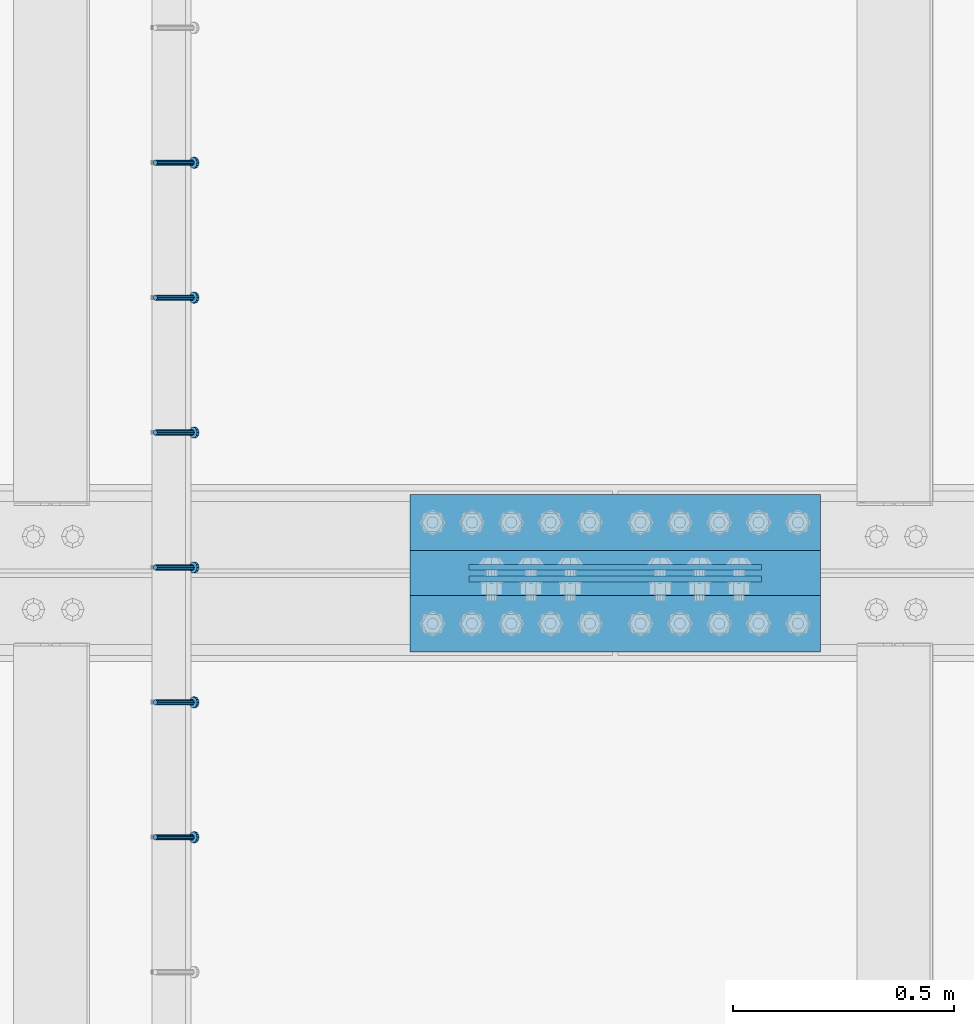
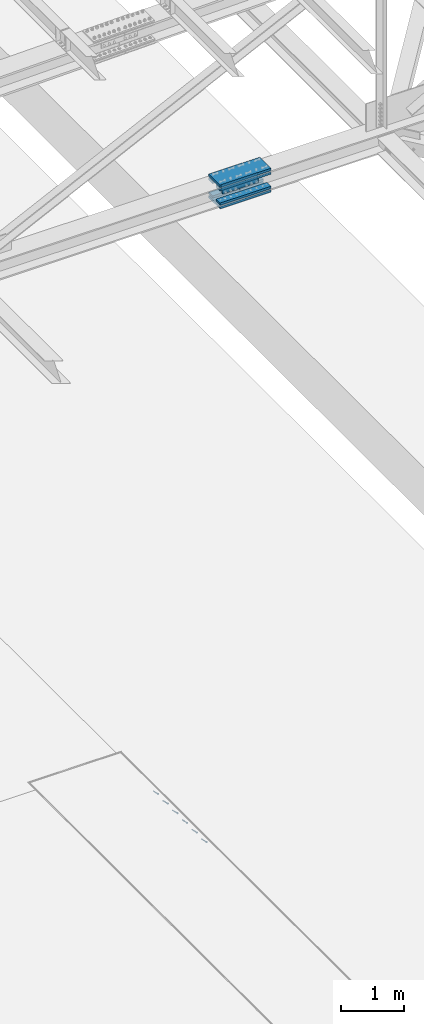
# One storey, part 2348 of 3843: 8 beams, 6 members, 2 elements without a shape of their own.
"""IFC2X3 building model written with IfcOpenShell, lengths in millimetres."""

from ifc_helpers import new_model, si_unit, frame, origin_with_axes, place, context, subcontext, project, spatial, faceted_brep, material, type_object, element, aggregate, save


model = new_model("IFC2X3")

# Units and contexts
model_context = context("Model", 3, precision=1e-05, world=origin_with_axes())
body_context = subcontext(model_context, "Body", "Model", "MODEL_VIEW")
ifc_project = project(units=[si_unit("LENGTHUNIT", "METRE", prefix="MILLI"), si_unit("AREAUNIT", "SQUARE_METRE"), si_unit("VOLUMEUNIT", "CUBIC_METRE"), si_unit("MASSUNIT", "GRAM", prefix="KILO"), si_unit("TIMEUNIT", "SECOND"), si_unit("PLANEANGLEUNIT", "RADIAN"), si_unit("SOLIDANGLEUNIT", "STERADIAN"), si_unit("THERMODYNAMICTEMPERATUREUNIT", "DEGREE_CELSIUS"), si_unit("LUMINOUSINTENSITYUNIT", "LUMEN")], contexts=[model_context])

# Site, building, storey
site_placement = place(None, origin_with_axes())
site = spatial("IfcSite", under=ifc_project, at=site_placement, CompositionType="ELEMENT")
building_placement = place(site_placement, origin_with_axes())
building = spatial("IfcBuilding", under=site, at=building_placement, Name="Undefined", CompositionType="ELEMENT")
storey_placement = place(building_placement, origin_with_axes())
storey = spatial("IfcBuildingStorey", under=building, at=storey_placement, Name="Undefined", CompositionType="ELEMENT", Elevation=0.0)

# Assembly, members
assembly_1_placement = place(storey_placement, origin_with_axes())
assembly_1 = element("IfcElementAssembly", 1, at=assembly_1_placement, inside=storey, Name="EMBED_ANGLE", AssemblyPlace="NOTDEFINED", PredefinedType="RIGID_FRAME")
ifc_material_1 = material(Name="STEEL/A108")
member_type = type_object("IfcMemberType", PredefinedType="NOTDEFINED")
member_1_placement = place(assembly_1_placement, frame((66677.3495, 49961.800201416, 30446.6625), z_axis=(0.0, 1.0, 0.0), x_axis=(0.707106781186548, 0.0, -0.707106781186548)))
member_1 = element("IfcMember", 2, at=member_1_placement, type_object=member_type, material=ifc_material_1, Name="HEADED STUD ANCHOR", context=body_context, shape_type="Brep", body=[
    faceted_brep([(7.27595761418343e-12, -3.18000006675175, 5.5), (0.0, -5.49999999998363, 3.1800000667572), (118.110000000976, -5.49999999999091, 3.1800000667572), (118.110000000983, -3.18000006675175, 5.5), (0.0, -6.3499999046162, 0.0), (118.110000000968, -6.34999990461256, 0.0), (0.0, -5.49999999998363, -3.1800000667572), (118.110000000976, -5.49999999999091, -3.1800000667572), (7.27595761418343e-12, -3.18000006675175, -5.5), (118.110000000983, -3.18000006675175, -5.5), (7.27595761418343e-12, -1.81898940354586e-12, -6.34999990463257), (118.110000000968, -1.81898940354586e-12, -6.34999990463257), (0.0, 3.18000006675175, -5.5), (118.110000000968, 3.18000006674811, -5.5), (7.27595761418343e-12, 5.49999999998363, -3.1800000667572), (118.110000000983, 5.49999999998363, -3.1800000667572), (7.27595761418343e-12, 6.3499999046162, 0.0), (118.110000000976, 6.34999990461256, 0.0), (7.27595761418343e-12, 5.49999999998363, 3.1800000667572), (118.110000000983, 5.49999999998363, 3.1800000667572), (0.0, 3.18000006675175, 5.5), (118.110000000968, 3.18000006674811, 5.5), (7.27595761418343e-12, -1.81898940354586e-12, 6.34999990463257), (118.110000000968, -1.81898940354586e-12, 6.34999990463257), (120.650000000991, -10.9899997710909, 6.34999990463257), (120.650000000998, -6.34000015257152, 10.9899997711182), (120.650000000991, -12.6999998092379, 0.0), (120.650000000991, -10.9899997710909, -6.34999990463257), (120.650000000998, -6.34000015257152, -10.9899997711182), (120.650000000991, -1.81898940354586e-12, -12.6899995803833), (120.650000000991, 6.34000015257152, -10.9899997711182), (120.650000000998, 10.9899997710909, -6.34999990463257), (120.650000000991, 12.6999998092342, 0.0), (120.650000000998, 10.9899997710909, 6.34999990463257), (120.650000000991, 6.34000015257152, 10.9899997711182), (120.650000000991, -1.81898940354586e-12, 12.6899995803833), (127.000000001048, -10.9899997710945, 6.34999990463257), (127.000000001048, -6.34000015257152, 10.9899997711182), (127.000000001048, -12.6999998092342, 0.0), (127.000000001048, -10.9899997710945, -6.34999990463257), (127.000000001048, -6.34000015257152, -10.9899997711182), (127.000000001048, 1.81898940354586e-12, -12.6899995803833), (127.000000001048, 6.34000015256788, -10.9899997711182), (127.000000001048, 10.9899997710909, -6.34999990463257), (127.000000001048, 12.6999998092379, 0.0), (127.000000001048, 10.9899997710909, 6.34999990463257), (127.000000001048, 6.34000015256788, 10.9899997711182), (127.000000001048, 1.81898940354586e-12, 12.6899995803833)], [[[0, 1, 2, 3]], [[1, 4, 5, 2]], [[4, 6, 7, 5]], [[6, 8, 9, 7]], [[8, 10, 11, 9]], [[10, 12, 13, 11]], [[12, 14, 15, 13]], [[14, 16, 17, 15]], [[16, 18, 19, 17]], [[18, 20, 21, 19]], [[20, 22, 23, 21]], [[22, 0, 3, 23]], [[22, 20, 18, 16, 14, 12, 10, 8, 6, 4, 1, 0]], [[3, 2, 24, 25]], [[2, 5, 26, 24]], [[5, 7, 27, 26]], [[7, 9, 28, 27]], [[9, 11, 29, 28]], [[11, 13, 30, 29]], [[13, 15, 31, 30]], [[15, 17, 32, 31]], [[17, 19, 33, 32]], [[19, 21, 34, 33]], [[21, 23, 35, 34]], [[23, 3, 25, 35]], [[25, 24, 36, 37]], [[24, 26, 38, 36]], [[26, 27, 39, 38]], [[27, 28, 40, 39]], [[28, 29, 41, 40]], [[29, 30, 42, 41]], [[30, 31, 43, 42]], [[31, 32, 44, 43]], [[32, 33, 45, 44]], [[33, 34, 46, 45]], [[34, 35, 47, 46]], [[35, 25, 37, 47]], [[38, 39, 40, 41, 42, 43, 44, 45, 46, 47, 37, 36]]]),
])
member_2_placement = place(assembly_1_placement, frame((66677.3495, 50266.600201416, 30446.6625), z_axis=(0.0, 1.0, 0.0), x_axis=(0.707106781186548, 0.0, -0.707106781186548)))
member_2 = element("IfcMember", 3, at=member_2_placement, type_object=member_type, material=ifc_material_1, Name="HEADED STUD ANCHOR", context=body_context, shape_type="Brep", body=[
    faceted_brep([(7.27595761418343e-12, -3.18000006675175, 5.5), (0.0, -5.49999999998363, 3.1800000667572), (118.110000000976, -5.49999999999091, 3.1800000667572), (118.110000000983, -3.18000006675175, 5.5), (0.0, -6.3499999046162, 0.0), (118.110000000968, -6.34999990461256, 0.0), (0.0, -5.49999999998363, -3.1800000667572), (118.110000000976, -5.49999999999091, -3.1800000667572), (7.27595761418343e-12, -3.18000006675175, -5.5), (118.110000000983, -3.18000006675175, -5.5), (7.27595761418343e-12, -1.81898940354586e-12, -6.34999990463257), (118.110000000968, -1.81898940354586e-12, -6.34999990463257), (0.0, 3.18000006675175, -5.5), (118.110000000968, 3.18000006674811, -5.5), (7.27595761418343e-12, 5.49999999998363, -3.1800000667572), (118.110000000983, 5.49999999998363, -3.1800000667572), (7.27595761418343e-12, 6.3499999046162, 0.0), (118.110000000976, 6.34999990461256, 0.0), (7.27595761418343e-12, 5.49999999998363, 3.1800000667572), (118.110000000983, 5.49999999998363, 3.1800000667572), (0.0, 3.18000006675175, 5.5), (118.110000000968, 3.18000006674811, 5.5), (7.27595761418343e-12, -1.81898940354586e-12, 6.34999990463257), (118.110000000968, -1.81898940354586e-12, 6.34999990463257), (120.650000000991, -10.9899997710909, 6.34999990463257), (120.650000000998, -6.34000015257152, 10.9899997711182), (120.650000000991, -12.6999998092379, 0.0), (120.650000000991, -10.9899997710909, -6.34999990463257), (120.650000000998, -6.34000015257152, -10.9899997711182), (120.650000000991, -1.81898940354586e-12, -12.6899995803833), (120.650000000991, 6.34000015257152, -10.9899997711182), (120.650000000998, 10.9899997710909, -6.34999990463257), (120.650000000991, 12.6999998092342, 0.0), (120.650000000998, 10.9899997710909, 6.34999990463257), (120.650000000991, 6.34000015257152, 10.9899997711182), (120.650000000991, -1.81898940354586e-12, 12.6899995803833), (127.000000001048, -10.9899997710945, 6.34999990463257), (127.000000001048, -6.34000015257152, 10.9899997711182), (127.000000001048, -12.6999998092342, 0.0), (127.000000001048, -10.9899997710945, -6.34999990463257), (127.000000001048, -6.34000015257152, -10.9899997711182), (127.000000001048, 1.81898940354586e-12, -12.6899995803833), (127.000000001048, 6.34000015256788, -10.9899997711182), (127.000000001048, 10.9899997710909, -6.34999990463257), (127.000000001048, 12.6999998092379, 0.0), (127.000000001048, 10.9899997710909, 6.34999990463257), (127.000000001048, 6.34000015256788, 10.9899997711182), (127.000000001048, 1.81898940354586e-12, 12.6899995803833)], [[[0, 1, 2, 3]], [[1, 4, 5, 2]], [[4, 6, 7, 5]], [[6, 8, 9, 7]], [[8, 10, 11, 9]], [[10, 12, 13, 11]], [[12, 14, 15, 13]], [[14, 16, 17, 15]], [[16, 18, 19, 17]], [[18, 20, 21, 19]], [[20, 22, 23, 21]], [[22, 0, 3, 23]], [[22, 20, 18, 16, 14, 12, 10, 8, 6, 4, 1, 0]], [[3, 2, 24, 25]], [[2, 5, 26, 24]], [[5, 7, 27, 26]], [[7, 9, 28, 27]], [[9, 11, 29, 28]], [[11, 13, 30, 29]], [[13, 15, 31, 30]], [[15, 17, 32, 31]], [[17, 19, 33, 32]], [[19, 21, 34, 33]], [[21, 23, 35, 34]], [[23, 3, 25, 35]], [[25, 24, 36, 37]], [[24, 26, 38, 36]], [[26, 27, 39, 38]], [[27, 28, 40, 39]], [[28, 29, 41, 40]], [[29, 30, 42, 41]], [[30, 31, 43, 42]], [[31, 32, 44, 43]], [[32, 33, 45, 44]], [[33, 34, 46, 45]], [[34, 35, 47, 46]], [[35, 25, 37, 47]], [[38, 39, 40, 41, 42, 43, 44, 45, 46, 47, 37, 36]]]),
])
member_3_placement = place(assembly_1_placement, frame((66677.3495, 50571.400201416, 30446.6625), z_axis=(0.0, 1.0, 0.0), x_axis=(0.707106781186548, 0.0, -0.707106781186548)))
member_3 = element("IfcMember", 4, at=member_3_placement, type_object=member_type, material=ifc_material_1, Name="HEADED STUD ANCHOR", context=body_context, shape_type="Brep", body=[
    faceted_brep([(7.27595761418343e-12, -3.18000006675175, 5.5), (0.0, -5.49999999998363, 3.1800000667572), (118.110000000976, -5.49999999999091, 3.1800000667572), (118.110000000983, -3.18000006675175, 5.5), (0.0, -6.3499999046162, 0.0), (118.110000000968, -6.34999990461256, 0.0), (0.0, -5.49999999998363, -3.1800000667572), (118.110000000976, -5.49999999999091, -3.1800000667572), (7.27595761418343e-12, -3.18000006675175, -5.5), (118.110000000983, -3.18000006675175, -5.5), (7.27595761418343e-12, -1.81898940354586e-12, -6.34999990463257), (118.110000000968, -1.81898940354586e-12, -6.34999990463257), (0.0, 3.18000006675175, -5.5), (118.110000000968, 3.18000006674811, -5.5), (7.27595761418343e-12, 5.49999999998363, -3.1800000667572), (118.110000000983, 5.49999999998363, -3.1800000667572), (7.27595761418343e-12, 6.3499999046162, 0.0), (118.110000000976, 6.34999990461256, 0.0), (7.27595761418343e-12, 5.49999999998363, 3.1800000667572), (118.110000000983, 5.49999999998363, 3.1800000667572), (0.0, 3.18000006675175, 5.5), (118.110000000968, 3.18000006674811, 5.5), (7.27595761418343e-12, -1.81898940354586e-12, 6.34999990463257), (118.110000000968, -1.81898940354586e-12, 6.34999990463257), (120.650000000991, -10.9899997710909, 6.34999990463257), (120.650000000998, -6.34000015257152, 10.9899997711182), (120.650000000991, -12.6999998092379, 0.0), (120.650000000991, -10.9899997710909, -6.34999990463257), (120.650000000998, -6.34000015257152, -10.9899997711182), (120.650000000991, -1.81898940354586e-12, -12.6899995803833), (120.650000000991, 6.34000015257152, -10.9899997711182), (120.650000000998, 10.9899997710909, -6.34999990463257), (120.650000000991, 12.6999998092342, 0.0), (120.650000000998, 10.9899997710909, 6.34999990463257), (120.650000000991, 6.34000015257152, 10.9899997711182), (120.650000000991, -1.81898940354586e-12, 12.6899995803833), (127.000000001048, -10.9899997710945, 6.34999990463257), (127.000000001048, -6.34000015257152, 10.9899997711182), (127.000000001048, -12.6999998092342, 0.0), (127.000000001048, -10.9899997710945, -6.34999990463257), (127.000000001048, -6.34000015257152, -10.9899997711182), (127.000000001048, 1.81898940354586e-12, -12.6899995803833), (127.000000001048, 6.34000015256788, -10.9899997711182), (127.000000001048, 10.9899997710909, -6.34999990463257), (127.000000001048, 12.6999998092379, 0.0), (127.000000001048, 10.9899997710909, 6.34999990463257), (127.000000001048, 6.34000015256788, 10.9899997711182), (127.000000001048, 1.81898940354586e-12, 12.6899995803833)], [[[0, 1, 2, 3]], [[1, 4, 5, 2]], [[4, 6, 7, 5]], [[6, 8, 9, 7]], [[8, 10, 11, 9]], [[10, 12, 13, 11]], [[12, 14, 15, 13]], [[14, 16, 17, 15]], [[16, 18, 19, 17]], [[18, 20, 21, 19]], [[20, 22, 23, 21]], [[22, 0, 3, 23]], [[22, 20, 18, 16, 14, 12, 10, 8, 6, 4, 1, 0]], [[3, 2, 24, 25]], [[2, 5, 26, 24]], [[5, 7, 27, 26]], [[7, 9, 28, 27]], [[9, 11, 29, 28]], [[11, 13, 30, 29]], [[13, 15, 31, 30]], [[15, 17, 32, 31]], [[17, 19, 33, 32]], [[19, 21, 34, 33]], [[21, 23, 35, 34]], [[23, 3, 25, 35]], [[25, 24, 36, 37]], [[24, 26, 38, 36]], [[26, 27, 39, 38]], [[27, 28, 40, 39]], [[28, 29, 41, 40]], [[29, 30, 42, 41]], [[30, 31, 43, 42]], [[31, 32, 44, 43]], [[32, 33, 45, 44]], [[33, 34, 46, 45]], [[34, 35, 47, 46]], [[35, 25, 37, 47]], [[38, 39, 40, 41, 42, 43, 44, 45, 46, 47, 37, 36]]]),
])
member_4_placement = place(assembly_1_placement, frame((66677.3495, 50876.200201416, 30446.6625), z_axis=(0.0, 1.0, 0.0), x_axis=(0.707106781186548, 0.0, -0.707106781186548)))
member_4 = element("IfcMember", 5, at=member_4_placement, type_object=member_type, material=ifc_material_1, Name="HEADED STUD ANCHOR", context=body_context, shape_type="Brep", body=[
    faceted_brep([(7.27595761418343e-12, -3.18000006675175, 5.5), (0.0, -5.49999999998363, 3.1800000667572), (118.110000000976, -5.49999999999091, 3.1800000667572), (118.110000000983, -3.18000006675175, 5.5), (0.0, -6.3499999046162, 0.0), (118.110000000968, -6.34999990461256, 0.0), (0.0, -5.49999999998363, -3.1800000667572), (118.110000000976, -5.49999999999091, -3.1800000667572), (7.27595761418343e-12, -3.18000006675175, -5.5), (118.110000000983, -3.18000006675175, -5.5), (7.27595761418343e-12, -1.81898940354586e-12, -6.34999990463257), (118.110000000968, -1.81898940354586e-12, -6.34999990463257), (0.0, 3.18000006675175, -5.5), (118.110000000968, 3.18000006674811, -5.5), (7.27595761418343e-12, 5.49999999998363, -3.1800000667572), (118.110000000983, 5.49999999998363, -3.1800000667572), (7.27595761418343e-12, 6.3499999046162, 0.0), (118.110000000976, 6.34999990461256, 0.0), (7.27595761418343e-12, 5.49999999998363, 3.1800000667572), (118.110000000983, 5.49999999998363, 3.1800000667572), (0.0, 3.18000006675175, 5.5), (118.110000000968, 3.18000006674811, 5.5), (7.27595761418343e-12, -1.81898940354586e-12, 6.34999990463257), (118.110000000968, -1.81898940354586e-12, 6.34999990463257), (120.650000000991, -10.9899997710909, 6.34999990463257), (120.650000000998, -6.34000015257152, 10.9899997711182), (120.650000000991, -12.6999998092379, 0.0), (120.650000000991, -10.9899997710909, -6.34999990463257), (120.650000000998, -6.34000015257152, -10.9899997711182), (120.650000000991, -1.81898940354586e-12, -12.6899995803833), (120.650000000991, 6.34000015257152, -10.9899997711182), (120.650000000998, 10.9899997710909, -6.34999990463257), (120.650000000991, 12.6999998092342, 0.0), (120.650000000998, 10.9899997710909, 6.34999990463257), (120.650000000991, 6.34000015257152, 10.9899997711182), (120.650000000991, -1.81898940354586e-12, 12.6899995803833), (127.000000001048, -10.9899997710945, 6.34999990463257), (127.000000001048, -6.34000015257152, 10.9899997711182), (127.000000001048, -12.6999998092342, 0.0), (127.000000001048, -10.9899997710945, -6.34999990463257), (127.000000001048, -6.34000015257152, -10.9899997711182), (127.000000001048, 1.81898940354586e-12, -12.6899995803833), (127.000000001048, 6.34000015256788, -10.9899997711182), (127.000000001048, 10.9899997710909, -6.34999990463257), (127.000000001048, 12.6999998092379, 0.0), (127.000000001048, 10.9899997710909, 6.34999990463257), (127.000000001048, 6.34000015256788, 10.9899997711182), (127.000000001048, 1.81898940354586e-12, 12.6899995803833)], [[[0, 1, 2, 3]], [[1, 4, 5, 2]], [[4, 6, 7, 5]], [[6, 8, 9, 7]], [[8, 10, 11, 9]], [[10, 12, 13, 11]], [[12, 14, 15, 13]], [[14, 16, 17, 15]], [[16, 18, 19, 17]], [[18, 20, 21, 19]], [[20, 22, 23, 21]], [[22, 0, 3, 23]], [[22, 20, 18, 16, 14, 12, 10, 8, 6, 4, 1, 0]], [[3, 2, 24, 25]], [[2, 5, 26, 24]], [[5, 7, 27, 26]], [[7, 9, 28, 27]], [[9, 11, 29, 28]], [[11, 13, 30, 29]], [[13, 15, 31, 30]], [[15, 17, 32, 31]], [[17, 19, 33, 32]], [[19, 21, 34, 33]], [[21, 23, 35, 34]], [[23, 3, 25, 35]], [[25, 24, 36, 37]], [[24, 26, 38, 36]], [[26, 27, 39, 38]], [[27, 28, 40, 39]], [[28, 29, 41, 40]], [[29, 30, 42, 41]], [[30, 31, 43, 42]], [[31, 32, 44, 43]], [[32, 33, 45, 44]], [[33, 34, 46, 45]], [[34, 35, 47, 46]], [[35, 25, 37, 47]], [[38, 39, 40, 41, 42, 43, 44, 45, 46, 47, 37, 36]]]),
])
member_5_placement = place(assembly_1_placement, frame((66677.3495, 51181.000201416, 30446.6625), z_axis=(0.0, 1.0, 0.0), x_axis=(0.707106781186548, 0.0, -0.707106781186548)))
member_5 = element("IfcMember", 6, at=member_5_placement, type_object=member_type, material=ifc_material_1, Name="HEADED STUD ANCHOR", context=body_context, shape_type="Brep", body=[
    faceted_brep([(7.27595761418343e-12, -3.18000006675175, 5.5), (0.0, -5.49999999998363, 3.1800000667572), (118.110000000976, -5.49999999999091, 3.1800000667572), (118.110000000983, -3.18000006675175, 5.5), (0.0, -6.3499999046162, 0.0), (118.110000000968, -6.34999990461256, 0.0), (0.0, -5.49999999998363, -3.1800000667572), (118.110000000976, -5.49999999999091, -3.1800000667572), (7.27595761418343e-12, -3.18000006675175, -5.5), (118.110000000983, -3.18000006675175, -5.5), (7.27595761418343e-12, -1.81898940354586e-12, -6.34999990463257), (118.110000000968, -1.81898940354586e-12, -6.34999990463257), (0.0, 3.18000006675175, -5.5), (118.110000000968, 3.18000006674811, -5.5), (7.27595761418343e-12, 5.49999999998363, -3.1800000667572), (118.110000000983, 5.49999999998363, -3.1800000667572), (7.27595761418343e-12, 6.3499999046162, 0.0), (118.110000000976, 6.34999990461256, 0.0), (7.27595761418343e-12, 5.49999999998363, 3.1800000667572), (118.110000000983, 5.49999999998363, 3.1800000667572), (0.0, 3.18000006675175, 5.5), (118.110000000968, 3.18000006674811, 5.5), (7.27595761418343e-12, -1.81898940354586e-12, 6.34999990463257), (118.110000000968, -1.81898940354586e-12, 6.34999990463257), (120.650000000991, -10.9899997710909, 6.34999990463257), (120.650000000998, -6.34000015257152, 10.9899997711182), (120.650000000991, -12.6999998092379, 0.0), (120.650000000991, -10.9899997710909, -6.34999990463257), (120.650000000998, -6.34000015257152, -10.9899997711182), (120.650000000991, -1.81898940354586e-12, -12.6899995803833), (120.650000000991, 6.34000015257152, -10.9899997711182), (120.650000000998, 10.9899997710909, -6.34999990463257), (120.650000000991, 12.6999998092342, 0.0), (120.650000000998, 10.9899997710909, 6.34999990463257), (120.650000000991, 6.34000015257152, 10.9899997711182), (120.650000000991, -1.81898940354586e-12, 12.6899995803833), (127.000000001048, -10.9899997710945, 6.34999990463257), (127.000000001048, -6.34000015257152, 10.9899997711182), (127.000000001048, -12.6999998092342, 0.0), (127.000000001048, -10.9899997710945, -6.34999990463257), (127.000000001048, -6.34000015257152, -10.9899997711182), (127.000000001048, 1.81898940354586e-12, -12.6899995803833), (127.000000001048, 6.34000015256788, -10.9899997711182), (127.000000001048, 10.9899997710909, -6.34999990463257), (127.000000001048, 12.6999998092379, 0.0), (127.000000001048, 10.9899997710909, 6.34999990463257), (127.000000001048, 6.34000015256788, 10.9899997711182), (127.000000001048, 1.81898940354586e-12, 12.6899995803833)], [[[0, 1, 2, 3]], [[1, 4, 5, 2]], [[4, 6, 7, 5]], [[6, 8, 9, 7]], [[8, 10, 11, 9]], [[10, 12, 13, 11]], [[12, 14, 15, 13]], [[14, 16, 17, 15]], [[16, 18, 19, 17]], [[18, 20, 21, 19]], [[20, 22, 23, 21]], [[22, 0, 3, 23]], [[22, 20, 18, 16, 14, 12, 10, 8, 6, 4, 1, 0]], [[3, 2, 24, 25]], [[2, 5, 26, 24]], [[5, 7, 27, 26]], [[7, 9, 28, 27]], [[9, 11, 29, 28]], [[11, 13, 30, 29]], [[13, 15, 31, 30]], [[15, 17, 32, 31]], [[17, 19, 33, 32]], [[19, 21, 34, 33]], [[21, 23, 35, 34]], [[23, 3, 25, 35]], [[25, 24, 36, 37]], [[24, 26, 38, 36]], [[26, 27, 39, 38]], [[27, 28, 40, 39]], [[28, 29, 41, 40]], [[29, 30, 42, 41]], [[30, 31, 43, 42]], [[31, 32, 44, 43]], [[32, 33, 45, 44]], [[33, 34, 46, 45]], [[34, 35, 47, 46]], [[35, 25, 37, 47]], [[38, 39, 40, 41, 42, 43, 44, 45, 46, 47, 37, 36]]]),
])
member_6_placement = place(assembly_1_placement, frame((66677.3495, 51485.800201416, 30446.6625), z_axis=(0.0, 1.0, 0.0), x_axis=(0.707106781186548, 0.0, -0.707106781186548)))
member_6 = element("IfcMember", 7, at=member_6_placement, type_object=member_type, material=ifc_material_1, Name="HEADED STUD ANCHOR", context=body_context, shape_type="Brep", body=[
    faceted_brep([(7.27595761418343e-12, -3.18000006675175, 5.5), (0.0, -5.49999999998363, 3.1800000667572), (118.110000000976, -5.49999999999091, 3.1800000667572), (118.110000000983, -3.18000006675175, 5.5), (0.0, -6.3499999046162, 0.0), (118.110000000968, -6.34999990461256, 0.0), (0.0, -5.49999999998363, -3.1800000667572), (118.110000000976, -5.49999999999091, -3.1800000667572), (7.27595761418343e-12, -3.18000006675175, -5.5), (118.110000000983, -3.18000006675175, -5.5), (7.27595761418343e-12, -1.81898940354586e-12, -6.34999990463257), (118.110000000968, -1.81898940354586e-12, -6.34999990463257), (0.0, 3.18000006675175, -5.5), (118.110000000968, 3.18000006674811, -5.5), (7.27595761418343e-12, 5.49999999998363, -3.1800000667572), (118.110000000983, 5.49999999998363, -3.1800000667572), (7.27595761418343e-12, 6.3499999046162, 0.0), (118.110000000976, 6.34999990461256, 0.0), (7.27595761418343e-12, 5.49999999998363, 3.1800000667572), (118.110000000983, 5.49999999998363, 3.1800000667572), (0.0, 3.18000006675175, 5.5), (118.110000000968, 3.18000006674811, 5.5), (7.27595761418343e-12, -1.81898940354586e-12, 6.34999990463257), (118.110000000968, -1.81898940354586e-12, 6.34999990463257), (120.650000000991, -10.9899997710909, 6.34999990463257), (120.650000000998, -6.34000015257152, 10.9899997711182), (120.650000000991, -12.6999998092379, 0.0), (120.650000000991, -10.9899997710909, -6.34999990463257), (120.650000000998, -6.34000015257152, -10.9899997711182), (120.650000000991, -1.81898940354586e-12, -12.6899995803833), (120.650000000991, 6.34000015257152, -10.9899997711182), (120.650000000998, 10.9899997710909, -6.34999990463257), (120.650000000991, 12.6999998092342, 0.0), (120.650000000998, 10.9899997710909, 6.34999990463257), (120.650000000991, 6.34000015257152, 10.9899997711182), (120.650000000991, -1.81898940354586e-12, 12.6899995803833), (127.000000001048, -10.9899997710945, 6.34999990463257), (127.000000001048, -6.34000015257152, 10.9899997711182), (127.000000001048, -12.6999998092342, 0.0), (127.000000001048, -10.9899997710945, -6.34999990463257), (127.000000001048, -6.34000015257152, -10.9899997711182), (127.000000001048, 1.81898940354586e-12, -12.6899995803833), (127.000000001048, 6.34000015256788, -10.9899997711182), (127.000000001048, 10.9899997710909, -6.34999990463257), (127.000000001048, 12.6999998092379, 0.0), (127.000000001048, 10.9899997710909, 6.34999990463257), (127.000000001048, 6.34000015256788, 10.9899997711182), (127.000000001048, 1.81898940354586e-12, 12.6899995803833)], [[[0, 1, 2, 3]], [[1, 4, 5, 2]], [[4, 6, 7, 5]], [[6, 8, 9, 7]], [[8, 10, 11, 9]], [[10, 12, 13, 11]], [[12, 14, 15, 13]], [[14, 16, 17, 15]], [[16, 18, 19, 17]], [[18, 20, 21, 19]], [[20, 22, 23, 21]], [[22, 0, 3, 23]], [[22, 20, 18, 16, 14, 12, 10, 8, 6, 4, 1, 0]], [[3, 2, 24, 25]], [[2, 5, 26, 24]], [[5, 7, 27, 26]], [[7, 9, 28, 27]], [[9, 11, 29, 28]], [[11, 13, 30, 29]], [[13, 15, 31, 30]], [[15, 17, 32, 31]], [[17, 19, 33, 32]], [[19, 21, 34, 33]], [[21, 23, 35, 34]], [[23, 3, 25, 35]], [[25, 24, 36, 37]], [[24, 26, 38, 36]], [[26, 27, 39, 38]], [[27, 28, 40, 39]], [[28, 29, 41, 40]], [[29, 30, 42, 41]], [[30, 31, 43, 42]], [[31, 32, 44, 43]], [[32, 33, 45, 44]], [[33, 34, 46, 45]], [[34, 35, 47, 46]], [[35, 25, 37, 47]], [[38, 39, 40, 41, 42, 43, 44, 45, 46, 47, 37, 36]]]),
])
aggregate(assembly_1, [member_1, member_2, member_3, member_4, member_5, member_6])

# Assembly, beams
assembly_2_placement = place(storey_placement, origin_with_axes())
assembly_2 = element("IfcElementAssembly", 8, at=assembly_2_placement, inside=storey, Name="BEAM", AssemblyPlace="NOTDEFINED", PredefinedType="RIGID_FRAME")
ifc_material_2 = material(Name="STEEL/A572-50")
beam_type_1 = type_object("IfcBeamType", PredefinedType="NOTDEFINED")
beam_1_placement = place(assembly_2_placement, frame((68046.5999947969, 50572.1937469886, 42344.4237563787), z_axis=(-0.000178361000012955, 0.0, 0.999999984093677), x_axis=(-0.999999984093677, 0.0, -0.000178361000011789)))
beam_1 = element("IfcBeam", 9, at=beam_1_placement, type_object=beam_type_1, material=ifc_material_2, Name="PLATE", context=body_context, shape_type="Brep", body=[
    faceted_brep([(1.45519152283669e-11, 6.35000000000582, -88.8999999998996), (0.0, 6.34999999999854, 88.9000015258789), (660.399999982677, 6.35000000000582, 88.8999999999651), (660.399999982707, 6.35000000000582, -88.8999999998268), (0.0, -6.34999999999854, 88.9000015258789), (660.399999982677, -6.35000000000582, 88.8999999999651), (1.45519152283669e-11, -6.35000000000582, -88.8999999998996), (660.399999982707, -6.35000000000582, -88.8999999998268)], [[[0, 1, 2, 3]], [[1, 4, 5, 2]], [[4, 6, 7, 5]], [[6, 0, 3, 7]], [[5, 7, 3, 2]], [[6, 4, 1, 0]]]),
])
beam_2_placement = place(assembly_2_placement, frame((68046.5999947969, 50545.2062469886, 42344.4237563787), z_axis=(-0.000178361000012955, 0.0, 0.999999984093677), x_axis=(-0.999999984093677, 0.0, -0.000178361000011789)))
beam_2 = element("IfcBeam", 10, at=beam_2_placement, type_object=beam_type_1, material=ifc_material_2, Name="PLATE", context=body_context, shape_type="Brep", body=[
    faceted_brep([(1.45519152283669e-11, 6.35000000000582, -88.8999999998996), (0.0, 6.34999999999854, 88.9000015258789), (660.399999982677, 6.35000000000582, 88.8999999999651), (660.399999982707, 6.35000000000582, -88.8999999998268), (0.0, -6.34999999999854, 88.9000015258789), (660.399999982677, -6.35000000000582, 88.8999999999651), (1.45519152283669e-11, -6.35000000000582, -88.8999999998996), (660.399999982707, -6.35000000000582, -88.8999999998268)], [[[0, 1, 2, 3]], [[1, 4, 5, 2]], [[4, 6, 7, 5]], [[6, 0, 3, 7]], [[5, 7, 3, 2]], [[6, 4, 1, 0]]]),
])
beam_type_2 = type_object("IfcBeamType", PredefinedType="NOTDEFINED")
beam_3_placement = place(assembly_2_placement, frame((68179.9131836166, 50558.6999969886, 42550.8217147474), z_axis=(0.0, 1.0, 0.0), x_axis=(-0.999999984093677, 0.0, -0.000178361000011789)))
beam_3 = element("IfcBeam", 11, at=beam_3_placement, type_object=beam_type_2, material=ifc_material_2, Name="PLATE", context=body_context, shape_type="Brep", body=[
    faceted_brep([(0.0, 22.2249999999767, -177.800000000003), (0.0, 22.2249999999767, 177.800000000003), (927.099999958984, 22.2250000000859, 177.800000000003), (927.099999958984, 22.2250000000859, -177.800000000003), (0.0, -22.2249999999694, 177.800000000003), (927.099999958984, -22.2249999998749, 177.800000000003), (0.0, -22.2249999999694, -177.800000000003), (927.099999958984, -22.2249999998749, -177.800000000003)], [[[0, 1, 2, 3]], [[1, 4, 5, 2]], [[4, 6, 7, 5]], [[6, 0, 3, 7]], [[5, 7, 3, 2]], [[6, 4, 1, 0]]]),
])
beam_4_placement = place(assembly_2_placement, frame((68179.9919284431, 50558.6999969886, 42137.9935896604), z_axis=(0.0, 1.0, 0.0), x_axis=(-0.999999984093677, 0.0, -0.000178361000011789)))
beam_4 = element("IfcBeam", 12, at=beam_4_placement, type_object=beam_type_2, material=ifc_material_2, Name="PLATE", context=body_context, shape_type="Brep", body=[
    faceted_brep([(0.0, 22.2249999999767, -177.800000000003), (0.0, 22.2249999999767, 177.800000000003), (927.099999958984, 22.2250000000859, 177.800000000003), (927.099999958984, 22.2250000000859, -177.800000000003), (0.0, -22.2249999999694, 177.800000000003), (927.099999958984, -22.2249999998749, 177.800000000003), (0.0, -22.2249999999694, -177.800000000003), (927.099999958984, -22.2249999998749, -177.800000000003)], [[[0, 1, 2, 3]], [[1, 4, 5, 2]], [[4, 6, 7, 5]], [[6, 0, 3, 7]], [[5, 7, 3, 2]], [[6, 4, 1, 0]]]),
])
beam_type_3 = type_object("IfcBeamType", PredefinedType="NOTDEFINED")
beam_5_placement = place(assembly_2_placement, frame((67252.8746527843, 50672.9999969886, 42206.1051235208), z_axis=(0.0, 1.0, 0.0), x_axis=(0.999999984093677, 0.0, 0.000178361000020154)))
beam_5 = element("IfcBeam", 13, at=beam_5_placement, type_object=beam_type_3, material=ifc_material_2, Name="PLATE", context=body_context, shape_type="Brep", body=[
    faceted_brep([(-7.27595761418343e-11, 22.2250000000786, -63.5), (-7.27595761418343e-11, 22.2250000000786, 63.5), (927.099999951592, 22.2250000031054, 63.5), (927.099999951592, 22.2250000031054, -63.5), (6.54836185276508e-11, -22.2250000000713, 63.5), (927.099999951744, -22.2249999970372, 63.5), (6.54836185276508e-11, -22.2250000000713, -63.5), (927.099999951744, -22.2249999970372, -63.5)], [[[0, 1, 2, 3]], [[1, 4, 5, 2]], [[4, 6, 7, 5]], [[6, 0, 3, 7]], [[5, 7, 3, 2]], [[6, 4, 1, 0]]]),
])
beam_6_placement = place(assembly_2_placement, frame((67252.8253876468, 50444.3999969886, 42482.3157258505), z_axis=(0.0, 1.0, 0.0), x_axis=(0.999999984093677, 0.0, 0.000178361000020154)))
beam_6 = element("IfcBeam", 14, at=beam_6_placement, type_object=beam_type_3, material=ifc_material_2, Name="PLATE", context=body_context, shape_type="Brep", body=[
    faceted_brep([(-7.27595761418343e-11, 22.2250000000786, -63.5), (-7.27595761418343e-11, 22.2250000000786, 63.5), (927.099999951592, 22.2250000031054, 63.5), (927.099999951592, 22.2250000031054, -63.5), (6.54836185276508e-11, -22.2250000000713, 63.5), (927.099999951744, -22.2249999970372, 63.5), (6.54836185276508e-11, -22.2250000000713, -63.5), (927.099999951744, -22.2249999970372, -63.5)], [[[0, 1, 2, 3]], [[1, 4, 5, 2]], [[4, 6, 7, 5]], [[6, 0, 3, 7]], [[5, 7, 3, 2]], [[6, 4, 1, 0]]]),
])
beam_7_placement = place(assembly_2_placement, frame((67252.8253876468, 50672.9999969886, 42482.3157258505), z_axis=(0.0, 1.0, 0.0), x_axis=(0.999999984093677, 0.0, 0.000178361000020154)))
beam_7 = element("IfcBeam", 15, at=beam_7_placement, type_object=beam_type_3, material=ifc_material_2, Name="PLATE", context=body_context, shape_type="Brep", body=[
    faceted_brep([(-7.27595761418343e-11, 22.2250000000786, -63.5), (-7.27595761418343e-11, 22.2250000000786, 63.5), (927.099999951592, 22.2250000031054, 63.5), (927.099999951592, 22.2250000031054, -63.5), (6.54836185276508e-11, -22.2250000000713, 63.5), (927.099999951744, -22.2249999970372, 63.5), (6.54836185276508e-11, -22.2250000000713, -63.5), (927.099999951744, -22.2249999970372, -63.5)], [[[0, 1, 2, 3]], [[1, 4, 5, 2]], [[4, 6, 7, 5]], [[6, 0, 3, 7]], [[5, 7, 3, 2]], [[6, 4, 1, 0]]]),
])
beam_8_placement = place(assembly_2_placement, frame((67252.8746527843, 50444.3999969886, 42206.1051235208), z_axis=(0.0, 1.0, 0.0), x_axis=(0.999999984093677, 0.0, 0.000178361000020154)))
beam_8 = element("IfcBeam", 16, at=beam_8_placement, type_object=beam_type_3, material=ifc_material_2, Name="PLATE", context=body_context, shape_type="Brep", body=[
    faceted_brep([(-7.27595761418343e-11, 22.2250000000786, -63.5), (-7.27595761418343e-11, 22.2250000000786, 63.5), (927.099999951592, 22.2250000031054, 63.5), (927.099999951592, 22.2250000031054, -63.5), (6.54836185276508e-11, -22.2250000000713, 63.5), (927.099999951744, -22.2249999970372, 63.5), (6.54836185276508e-11, -22.2250000000713, -63.5), (927.099999951744, -22.2249999970372, -63.5)], [[[0, 1, 2, 3]], [[1, 4, 5, 2]], [[4, 6, 7, 5]], [[6, 0, 3, 7]], [[5, 7, 3, 2]], [[6, 4, 1, 0]]]),
])
aggregate(assembly_2, [beam_1, beam_3, beam_5, beam_6, beam_7, beam_8, beam_4, beam_2])

save(model, "model.ifc")
